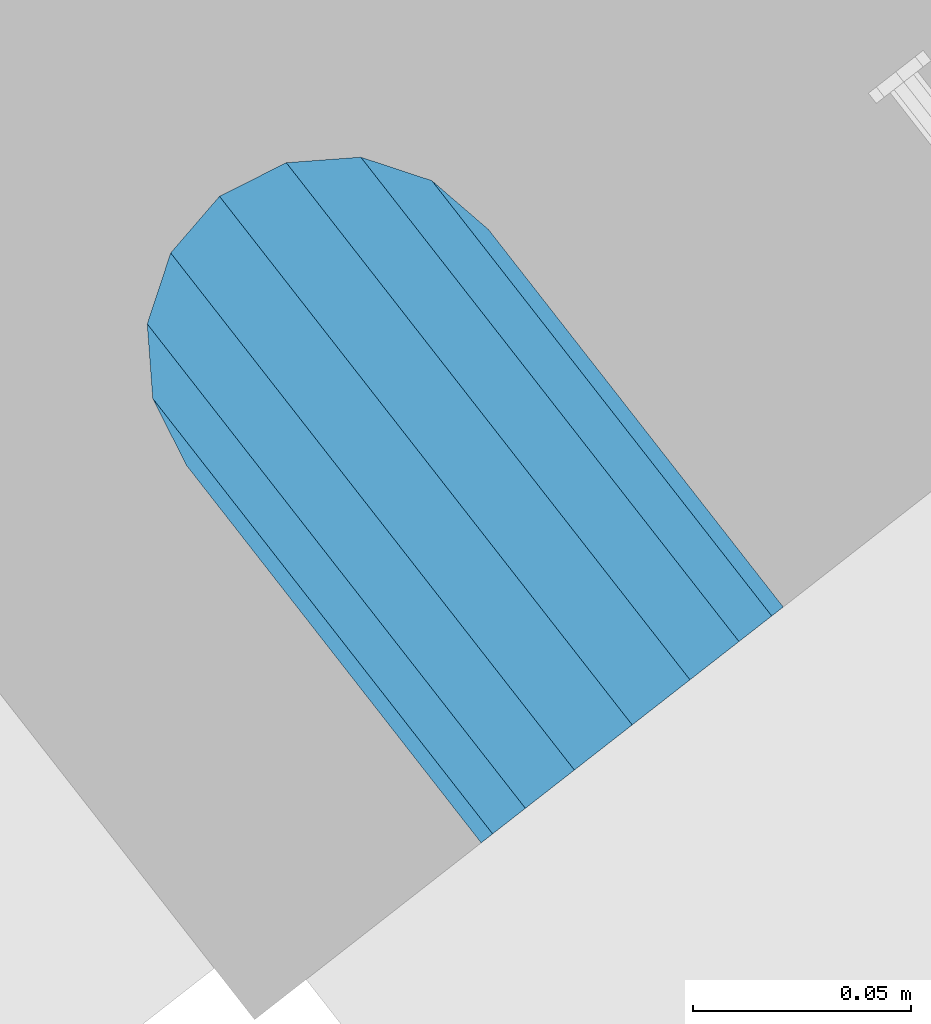
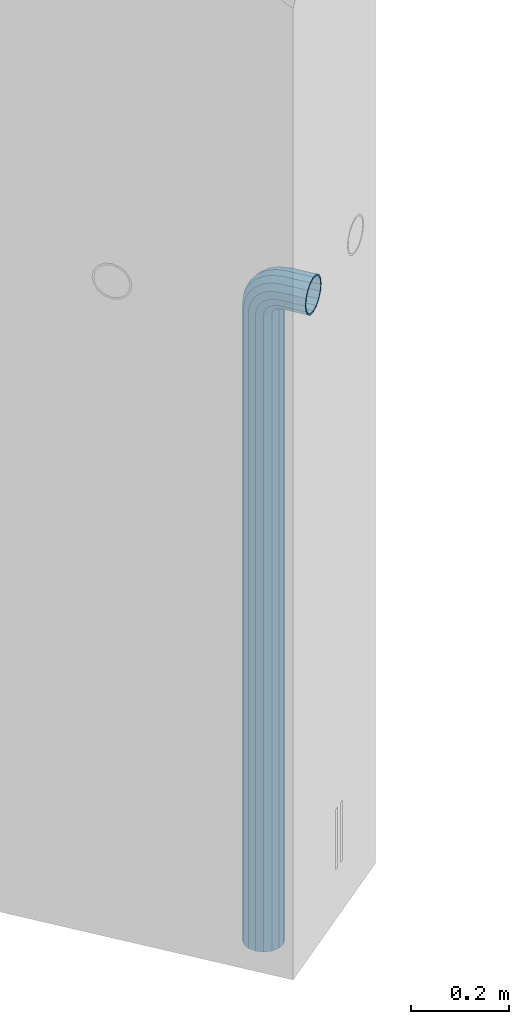
# One storey, part 4 of 42: 1 beam, 2 elements without a shape of their own.
"""IFC2X3 building model written with IfcOpenShell, lengths in millimetres."""

from ifc_helpers import new_model, si_unit, frame, origin_with_axes, place, context, subcontext, project, spatial, faceted_brep, material, type_object, element, aggregate, save


model = new_model("IFC2X3")

# Units and contexts
model_context = context("Model", 3, precision=1e-05, world=origin_with_axes())
body_context = subcontext(model_context, "Body", "Model", "MODEL_VIEW")
ifc_project = project(units=[si_unit("LENGTHUNIT", "METRE", prefix="MILLI"), si_unit("AREAUNIT", "SQUARE_METRE"), si_unit("VOLUMEUNIT", "CUBIC_METRE"), si_unit("MASSUNIT", "GRAM", prefix="KILO"), si_unit("TIMEUNIT", "SECOND"), si_unit("PLANEANGLEUNIT", "RADIAN"), si_unit("SOLIDANGLEUNIT", "STERADIAN"), si_unit("THERMODYNAMICTEMPERATUREUNIT", "DEGREE_CELSIUS"), si_unit("LUMINOUSINTENSITYUNIT", "LUMEN")], contexts=[model_context])

# Site, building, storey
site_placement = place(None, frame((171687.4, 84828.52, 14700.0), z_axis=(0.0, 0.0, 1.0), x_axis=(1.0, 0.0, 0.0)))
site = spatial("IfcSite", under=ifc_project, at=site_placement, CompositionType="ELEMENT")
building_placement = place(site_placement, origin_with_axes())
building = spatial("IfcBuilding", under=site, at=building_placement, Name="Undefined", CompositionType="ELEMENT")
storey_placement = place(building_placement, origin_with_axes())
storey = spatial("IfcBuildingStorey", under=building, at=storey_placement, Name="Undefined", CompositionType="ELEMENT", Elevation=0.0)

# Assemblies, beam
assembly_1_placement = place(storey_placement, origin_with_axes())
assembly_1 = element("IfcElementAssembly", 1, at=assembly_1_placement, inside=storey, AssemblyPlace="NOTDEFINED", PredefinedType="REINFORCEMENT_UNIT")
assembly_2_placement = place(assembly_1_placement, origin_with_axes())
assembly_2 = element("IfcElementAssembly", 2, at=assembly_2_placement, AssemblyPlace="NOTDEFINED", PredefinedType="RIGID_FRAME")
aggregate(assembly_1, [assembly_2])
ifc_material = material(Name="STEEL/NEG_BETON")
beam_type = type_object("IfcBeamType", PredefinedType="NOTDEFINED")
beam_placement = place(assembly_2_placement, frame((18184.6017728418, 265049.933547208, -1290.0), z_axis=(0.615386370178831, -0.788225611990706, 0.0), x_axis=(0.0, 0.0, 1.0)))
beam = element("IfcBeam", 3, at=beam_placement, type_object=beam_type, material=ifc_material, context=body_context, shape_type="Brep", body=[
    faceted_brep([(0.0, -43.999999753345, 2.88331648334861e-07), (0.0, -40.6506991838105, -16.8380707357428), (1590.0, -40.6506991838105, -16.8380707357428), (1589.99999999999, -43.999999753345, 2.88331648334861e-07), (0.0, -31.1126981254783, -31.1126980838017), (1590.0, -31.1126981254783, -31.1126980838017), (0.0, -16.8380707773322, -40.6506991419883), (1590.0, -16.8380707773322, -40.6506991419883), (0.0, 2.46742274612188e-07, -43.9999997114064), (1590.0, 2.46742274612188e-07, -43.9999997114064), (0.0, 16.8380712707876, -40.6506991418137), (1590.0, 16.8380712707876, -40.6506991418137), (0.0, 31.1126986189047, -31.1126980834524), (1590.0, 31.1126986189047, -31.1126980834524), (0.0, 40.6506996771204, -16.8380707352771), (1590.0, 40.6506996771204, -16.8380707352771), (0.0, 44.0000002465677, 2.88768205791712e-07), (1590.0, 44.0000002465677, 2.88768205791712e-07), (0.0, 40.6506996770622, 16.8380713128427), (1590.0, 40.6506996770622, 16.8380713128427), (0.0, 31.1126986187301, 31.1126986609306), (1590.0, 31.1126986187301, 31.1126986609306), (0.0, 16.8380712705839, 40.6506997191464), (1590.0, 16.8380712705839, 40.6506997191464), (0.0, 2.46509443968534e-07, 44.0000002885354), (1590.0, 2.46509443968534e-07, 44.0000002885354), (0.0, -16.8380707775359, 40.6506997189426), (1590.0, -16.8380707775359, 40.6506997189426), (0.0, -31.1126981256821, 31.1126986605814), (1590.0, -31.1126981256821, 31.1126986605814), (0.0, -40.6506991838978, 16.838071312377), (1590.0, -40.6506991838978, 16.838071312377), (4.47878846898675e-07, -40.0000000634464, 0.0), (4.47878846898675e-07, -36.9551813638827, 15.3073372946019), (1590.0, -36.9551810538396, 15.3073375829845), (1589.99999999999, -39.999999753345, 2.88360752165318e-07), (4.47937054559588e-07, -28.2842713108694, 28.284271247463), (1590.0, -28.2842710008845, 28.2842715359002), (4.4800981413573e-07, -15.3073373580119, 36.9551813004509), (1590.0, -15.3073370480561, 36.9551815889135), (4.48068021796644e-07, -6.34463503956795e-08, 40.0), (1590.0, 2.46538547798991e-07, 40.0000002885645), (4.48140781372786e-07, 15.3073372311774, 36.9551813004509), (1590.0, 15.3073375411332, 36.9551815890882), (4.48213540948927e-07, 28.2842711840058, 28.284271247463), (1590.0, 28.2842714939907, 28.2842715361621), (4.48271748609841e-07, 36.95518123699, 15.3073372946019), (1590.0, 36.9551815469749, 15.3073375833046), (4.48286300525069e-07, 39.9999999365536, 0.0), (1590.0, 40.0000002465677, 2.88768205791712e-07), (4.48271748609841e-07, 36.95518123699, -15.3073372946019), (1590.0, 36.9551815470913, -15.3073370058555), (4.48213540948927e-07, 28.2842711840058, -28.284271247463), (1590.0, 28.2842714941071, -28.2842709587712), (4.48140781372786e-07, 15.3073372311774, -36.9551813004509), (1590.0, 15.3073375413369, -36.9551810117846), (4.48068021796644e-07, -6.34463503956795e-08, -40.0), (1590.0, 2.46742274612188e-07, -39.9999997114064), (4.4800981413573e-07, -15.3073373580119, -36.9551813004509), (1590.0, -15.3073370479106, -36.9551810119592), (4.47937054559588e-07, -28.2842713108694, -28.284271247463), (1590.0, -28.284271000739, -28.2842709590332), (4.47878846898675e-07, -36.9551813638827, -15.3073372946019), (1590.0, -36.9551810537523, -15.3073370062048), (1602.94095225512, -43.9999997540726, 1.70370897403336), (1598.5829387913, -40.6506991846254, 17.9680366410757), (1594.88839337186, -31.1126981263515, 31.7562678573595), (1592.41977704577, -16.8380707782635, 40.9692694107944), (1591.55291427061, 2.45810952037573e-07, 44.2044453310082), (1592.41977704577, 16.8380712698563, 40.969269410969), (1594.88839337186, 31.1126986180025, 31.7562678576505), (1598.5829387913, 40.6506996763346, 17.9680366415123), (1602.94095225512, 44.0000002458692, 1.70370897452813), (1607.29896571893, 40.6506996763928, -14.5606186925434), (1610.99351113838, 31.112698618148, -28.3488499088271), (1613.46212746447, 16.83807127006, -37.561851462262), (1614.32899023963, 2.4601467885077e-07, -40.7970273824176), (1613.46212746447, -16.8380707780307, -37.5618514623784), (1610.99351113838, -31.1126981262059, -28.348849909089), (1607.29896571893, -40.650699184509, -14.5606186929217), (1613.29371405922, 2.45985575020313e-07, -36.9333240772539), (1612.50565699089, 15.3073375405802, -33.9922550588963), (1610.26146033081, 28.2842714934086, -25.6167991012626), (1606.90278267677, 36.9551815463637, -13.0820434500929), (1602.94095225512, 40.0000002458692, 1.70370897449902), (1598.97912183347, 36.9551815463055, 16.4894613990327), (1595.62044417943, 28.2842714932631, 29.024217050086), (1593.37624751934, 15.3073375403765, 37.3996730076324), (1592.58819045102, 2.45781848207116e-07, 40.3407420258154), (1593.37624751934, -15.3073370488128, 37.3996730074577), (1595.62044417943, -28.2842710016412, 29.0242170498241), (1598.97912183347, -36.9551810545672, 16.4894613986544), (1602.94095225512, -39.9999997540726, 1.70370897406247), (1606.90278267677, -36.955181054509, -13.0820434504712), (1610.26146033081, -28.2842710014374, -25.6167991015245), (1612.50565699089, -15.307337048609, -33.9922550590418), (1630.55634918609, 31.112698618148, -20.2456570709182), (1635.32534971524, 16.8380712700309, -28.5058082887845), (1623.41903551202, 40.6506996764219, -7.883467157837), (1614.99999999999, 44.0000002458692, 6.69873009974253), (1606.58096448796, 40.6506996763346, 21.2809273572639), (1599.44365081389, 31.1126986180025, 33.6431172702578), (1594.67465028474, 16.8380712698563, 41.9032684879785), (1592.99999999999, 2.45752744376659e-07, 44.8038478659873), (1594.67465028474, -16.8380707782635, 41.9032684878039), (1599.44365081389, -31.1126981263515, 33.6431172699668), (1606.58096448796, -40.6506991846254, 21.2809273568855), (1614.99999999999, -43.9999997540726, 6.69873009927687), (1623.41903551202, -40.6506991845672, -7.88346715827356), (1630.55634918609, -31.1126981262059, -20.2456570712384), (1635.32534971524, -16.8380707780598, -28.5058082889591), (1636.99999999999, 2.45956471189857e-07, -31.4063876669679), (1633.47759065022, -15.3073370486381, -25.3053957082157), (1634.99999999999, 2.45985575020313e-07, -27.9422860518389), (1629.14213562372, -28.2842710014665, -17.7961673284299), (1622.65366864729, -36.9551810545381, -6.55781286209822), (1614.99999999999, -39.9999997541017, 6.69873009933508), (1607.34633135269, -36.9551810545381, 19.9552730607684), (1600.85786437626, -28.2842710016121, 31.1936275271582), (1596.52240934976, -15.3073370487837, 38.7028559070604), (1594.99999999999, 2.45810952037573e-07, 41.3397462508583), (1596.52240934976, 15.3073375404056, 38.702855907206), (1600.85786437626, 28.2842714932631, 31.1936275275075), (1607.34633135269, 36.9551815462473, 19.9552730610885), (1614.99999999999, 40.0000002458692, 6.69873009974253), (1622.65366864729, 36.9551815463346, -6.55781286169076), (1629.14213562372, 28.2842714933795, -17.7961673281679), (1633.47759065022, 15.3073375405511, -25.305395708041), (1647.35533905931, 31.1126986181189, -7.35533877040143), (1654.09972428659, 16.8380712700018, -14.0997239977587), (1637.26165326252, 40.6506996763928, 2.73834702643217), (1625.35533905931, 44.0000002458401, 14.6446612296568), (1613.4490248561, 40.6506996763346, 26.5509754328523), (1603.35533905931, 31.1126986179734, 36.6446612295404), (1596.61095383203, 16.8380712698563, 43.3890464567812), (1594.24264068711, 2.45810952037573e-07, 45.7573596016155), (1596.61095383203, -16.8380707782344, 43.3890464565775), (1603.35533905931, -31.1126981263806, 36.6446612292202), (1613.4490248561, -40.6506991846254, 26.5509754324157), (1625.35533905931, -43.9999997541017, 14.644661229162), (1637.26165326252, -40.6506991845672, 2.73834702599561), (1647.35533905931, -31.1126981262641, -7.35533877075068), (1654.09972428659, -16.838070778118, -14.0997239979333), (1656.46803743151, 2.45956471189857e-07, -16.4680371427676), (1651.48659835683, -15.3073370486381, -11.4865980681498), (1653.63961030677, 2.45956471189857e-07, -13.6396100180573), (1645.35533905931, -28.2842710015248, -5.35533877072157), (1636.17926106223, -36.955181054509, 3.82073922632844), (1625.35533905931, -39.9999997541017, 14.6446612291911), (1614.53141705639, -36.9551810545672, 25.4685832321702), (1605.35533905931, -28.2842710016121, 34.6446612292784), (1599.22407976179, -15.3073370487837, 40.775920526823), (1597.07106781185, 2.45781848207116e-07, 42.9289324768179), (1599.22407976179, 15.3073375403765, 40.7759205269977), (1605.35533905931, 28.2842714932631, 34.6446612295404), (1614.53141705639, 36.9551815462764, 25.4685832324903), (1625.35533905931, 40.0000002458401, 14.6446612296277), (1636.17926106223, 36.9551815463346, 3.82073922670679), (1645.35533905931, 28.2842714933795, -5.35533877045964), (1651.48659835683, 15.307337540522, -11.4865980680042), (1660.24565735981, 31.1126986180607, 9.44365110280341), (1668.50580857761, 16.8380712699436, 4.67465057360823), (1647.88346744676, 40.6506996763055, 16.5809647768911), (1633.3012701892, 44.000000245811, 25.0000002889719), (1618.71907293164, 40.6506996763055, 33.4190358009655), (1606.35688301859, 31.1126986179734, 40.5563494749367), (1598.09673180079, 16.8380712698563, 45.3253500040737), (1595.19615242269, 2.45781848207116e-07, 47.00000028871), (1598.09673180079, -16.8380707782635, 45.32535000387), (1606.35688301859, -31.1126981263806, 40.5563494746748), (1618.71907293164, -40.6506991846545, 33.419035800558), (1633.3012701892, -43.9999997541308, 25.0000002884772), (1647.88346744676, -40.6506991845963, 16.5809647764836), (1660.24565735981, -31.1126981262933, 9.44365110251238), (1668.50580857761, -16.8380707781762, 4.67465057340451), (1671.40638795571, 2.459273673594e-07, 3.00000028876821), (1665.30539599684, -15.3073370486964, 6.52240963847726), (1667.94228634057, 2.45898263528943e-07, 5.00000028876821), (1657.79616761703, -28.2842710015539, 10.8578646648966), (1646.55781315062, -36.9551810545672, 17.3463316412526), (1633.3012701892, -39.9999997541308, 25.0000002885063), (1620.04472722778, -36.9551810546254, 32.6536689358181), (1608.80637276137, -28.2842710016412, 39.1421359122905), (1601.29714438156, -15.3073370488128, 43.4775909388554), (1598.66025403783, 2.45781848207116e-07, 45.0000002886809), (1601.29714438156, 15.3073375403765, 43.4775909390009), (1608.80637276137, 28.2842714932631, 39.1421359125816), (1620.04472722778, 36.9551815462473, 32.6536689362256), (1633.3012701892, 40.0000002458401, 25.0000002889428), (1646.55781315062, 36.9551815463055, 17.346331641631), (1657.79616761703, 28.2842714933213, 10.8578646651586), (1665.30539599684, 15.3073375404638, 6.52240963859367), (1668.34885019768, 31.1126986180316, 29.0064891505172), (1677.56185175105, 16.8380712698563, 26.5378728243522), (1654.56061898146, 40.6506996763055, 32.7010345700255), (1638.29629131443, 44.0000002457818, 37.0590480338433), (1622.0319636474, 40.6506996763055, 41.4170614976319), (1608.24373243118, 31.1126986179734, 45.1116069169948), (1599.03073087781, 16.8380712698563, 47.5802232430142), (1595.79555495772, 2.45781848207116e-07, 48.4470860181027), (1599.03073087781, -16.8380707782635, 47.5802232428396), (1608.24373243118, -31.1126981263806, 45.1116069167037), (1622.0319636474, -40.6506991846836, 41.4170614971954), (1638.29629131443, -43.9999997541599, 37.0590480333485), (1654.56061898146, -40.6506991846254, 32.701034569589), (1668.34885019768, -31.1126981263515, 29.006489150197), (1677.56185175105, -16.8380707782053, 26.5378728241776), (1680.79702767114, 2.4584005586803e-07, 25.6710100491182), (1673.99225534772, -15.3073370487546, 27.4943432977598), (1676.93332436598, 2.4584005586803e-07, 26.7062862295134), (1665.61679939011, -28.284271001583, 29.7385399577906), (1653.082043739, -36.9551810545963, 33.0972176117939), (1638.29629131443, -39.9999997541599, 37.0590480334067), (1623.51053888986, -36.9551810546545, 41.0208784550487), (1610.97578323875, -28.2842710016412, 44.3795561091392), (1602.60032728114, -15.3073370487837, 46.6237527692865), (1599.65925826287, 2.45810952037573e-07, 47.4118098377076), (1602.60032728114, 15.3073375403474, 46.623752769432), (1610.97578323875, 28.284271493234, 44.3795561094012), (1623.51053888986, 36.9551815462182, 41.0208784554561), (1638.29629131443, 40.0000002457818, 37.0590480338142), (1653.082043739, 36.9551815462473, 33.097217612114), (1665.61679939011, 28.2842714932631, 29.7385399580817), (1673.99225534772, 15.3073375404347, 27.4943432979344), (1671.11269837217, -31.1126981263806, 50.0000002885645), (1656.83807102403, -40.6506991847127, 50.0000002885063), (1680.65069943045, -16.8380707782635, 50.0000002886227), (1683.99999999996, 2.45781848207116e-07, 50.0000002887391), (1680.65069943045, 16.8380712698563, 50.0000002887973), (1671.11269837217, 31.1126986179734, 50.0000002888555), (1656.83807102403, 40.6506996762473, 50.0000002889428), (1639.99999999997, 44.0000002457236, 50.0000002889137), (1623.16192897591, 40.6506996762473, 50.0000002889428), (1608.88730162777, 31.1126986179734, 50.0000002888555), (1599.34930056949, 16.8380712698563, 50.0000002887973), (1595.99999999998, 2.45781848207116e-07, 50.0000002887391), (1599.34930056949, -16.8380707782635, 50.0000002886227), (1608.88730162777, -31.1126981263806, 50.0000002885645), (1623.16192897591, -40.6506991846836, 50.0000002885063), (1640.0, -43.999999754189, 50.0000002885063), (1676.95518130041, -15.3073370488128, 50.0000002886227), (1679.99999999996, 2.45781848207116e-07, 50.0000002887391), (1668.28427124742, -28.2842710016703, 50.0000002885645), (1655.30733729457, -36.9551810546545, 50.0000002885354), (1640.0, -39.999999754189, 50.0000002885063), (1624.69266270537, -36.9551810546545, 50.0000002885354), (1611.71572875252, -28.2842710016703, 50.0000002885645), (1603.04481869953, -15.3073370488128, 50.0000002886227), (1599.99999999998, 2.45781848207116e-07, 50.0000002887391), (1603.04481869953, 15.3073375403765, 50.0000002887973), (1611.71572875252, 28.284271493234, 50.0000002888555), (1624.69266270537, 36.9551815461891, 50.0000002888846), (1639.99999999997, 40.0000002457236, 50.0000002889137), (1655.30733729457, 36.9551815461891, 50.0000002889137), (1668.28427124742, 28.284271493234, 50.0000002888555), (1676.95518130041, 15.3073375403765, 50.0000002887973), (1656.83807102406, -40.6506991848582, 110.000000288477), (1640.0, -43.9999997543346, 110.000000288477), (1671.11269837221, -31.1126981265552, 110.000000288535), (1680.6506994305, -16.838070778409, 110.000000288594), (1684.0, 2.45607225224376e-07, 110.00000028871), (1680.6506994305, 16.8380712696817, 110.000000288768), (1671.11269837221, 31.1126986177987, 110.000000288826), (1656.83807102406, 40.6506996761018, 110.000000288914), (1640.0, 44.0000002455781, 110.000000288914), (1623.16192897594, 40.6506996761018, 110.000000288914), (1608.88730162779, 31.1126986177987, 110.000000288826), (1599.3493005695, 16.8380712696817, 110.000000288768), (1596.0, 2.45607225224376e-07, 110.00000028871), (1599.3493005695, -16.838070778409, 110.000000288594), (1608.88730162779, -31.1126981265552, 110.000000288535), (1623.16192897594, -40.6506991848582, 110.000000288477), (1624.6926627054, -36.9551810548001, 110.000000288535), (1640.0, -39.9999997543346, 110.000000288477), (1611.71572875254, -28.2842710018158, 110.000000288535), (1603.04481869955, -15.3073370489583, 110.000000288594), (1600.0, 2.45607225224376e-07, 110.00000028871), (1603.04481869955, 15.3073375402309, 110.000000288768), (1611.71572875254, 28.2842714930885, 110.000000288856), (1624.6926627054, 36.9551815460436, 110.000000288856), (1640.0, 40.0000002455781, 110.000000288885), (1655.3073372946, 36.9551815460436, 110.000000288856), (1668.28427124746, 28.2842714930885, 110.000000288856), (1676.95518130045, 15.3073375402309, 110.000000288768), (1680.0, 2.45607225224376e-07, 110.00000028871), (1676.95518130045, -15.3073370489583, 110.000000288594), (1668.28427124746, -28.2842710018158, 110.000000288535), (1655.3073372946, -36.9551810548001, 110.000000288535)], [[[0, 1, 2, 3]], [[1, 4, 5, 2]], [[4, 6, 7, 5]], [[6, 8, 9, 7]], [[8, 10, 11, 9]], [[10, 12, 13, 11]], [[12, 14, 15, 13]], [[14, 16, 17, 15]], [[16, 18, 19, 17]], [[18, 20, 21, 19]], [[20, 22, 23, 21]], [[22, 24, 25, 23]], [[24, 26, 27, 25]], [[26, 28, 29, 27]], [[28, 30, 31, 29]], [[30, 0, 3, 31]], [[32, 33, 34, 35]], [[33, 36, 37, 34]], [[36, 38, 39, 37]], [[38, 40, 41, 39]], [[40, 42, 43, 41]], [[42, 44, 45, 43]], [[44, 46, 47, 45]], [[46, 48, 49, 47]], [[48, 50, 51, 49]], [[50, 52, 53, 51]], [[52, 54, 55, 53]], [[54, 56, 57, 55]], [[56, 58, 59, 57]], [[58, 60, 61, 59]], [[60, 62, 63, 61]], [[62, 32, 35, 63]], [[30, 28, 26, 24, 22, 20, 18, 16, 14, 12, 10, 8, 6, 4, 1, 0], [62, 60, 58, 56, 54, 52, 50, 48, 46, 44, 42, 40, 38, 36, 33, 32]], [[31, 3, 64, 65]], [[29, 31, 65, 66]], [[27, 29, 66, 67]], [[25, 27, 67, 68]], [[23, 25, 68, 69]], [[21, 23, 69, 70]], [[19, 21, 70, 71]], [[17, 19, 71, 72]], [[15, 17, 72, 73]], [[13, 15, 73, 74]], [[11, 13, 74, 75]], [[9, 11, 75, 76]], [[7, 9, 76, 77]], [[5, 7, 77, 78]], [[2, 5, 78, 79]], [[3, 2, 79, 64]], [[55, 57, 80, 81]], [[53, 55, 81, 82]], [[51, 53, 82, 83]], [[49, 51, 83, 84]], [[47, 49, 84, 85]], [[45, 47, 85, 86]], [[43, 45, 86, 87]], [[41, 43, 87, 88]], [[39, 41, 88, 89]], [[37, 39, 89, 90]], [[34, 37, 90, 91]], [[35, 34, 91, 92]], [[63, 35, 92, 93]], [[61, 63, 93, 94]], [[59, 61, 94, 95]], [[57, 59, 95, 80]], [[74, 96, 97, 75]], [[73, 98, 96, 74]], [[72, 99, 98, 73]], [[71, 100, 99, 72]], [[70, 101, 100, 71]], [[69, 102, 101, 70]], [[68, 103, 102, 69]], [[67, 104, 103, 68]], [[66, 105, 104, 67]], [[65, 106, 105, 66]], [[64, 107, 106, 65]], [[79, 108, 107, 64]], [[78, 109, 108, 79]], [[77, 110, 109, 78]], [[76, 111, 110, 77]], [[75, 97, 111, 76]], [[95, 112, 113, 80]], [[94, 114, 112, 95]], [[93, 115, 114, 94]], [[92, 116, 115, 93]], [[91, 117, 116, 92]], [[90, 118, 117, 91]], [[89, 119, 118, 90]], [[88, 120, 119, 89]], [[87, 121, 120, 88]], [[86, 122, 121, 87]], [[85, 123, 122, 86]], [[84, 124, 123, 85]], [[83, 125, 124, 84]], [[82, 126, 125, 83]], [[81, 127, 126, 82]], [[80, 113, 127, 81]], [[96, 128, 129, 97]], [[98, 130, 128, 96]], [[99, 131, 130, 98]], [[100, 132, 131, 99]], [[101, 133, 132, 100]], [[102, 134, 133, 101]], [[103, 135, 134, 102]], [[104, 136, 135, 103]], [[105, 137, 136, 104]], [[106, 138, 137, 105]], [[107, 139, 138, 106]], [[108, 140, 139, 107]], [[109, 141, 140, 108]], [[110, 142, 141, 109]], [[111, 143, 142, 110]], [[97, 129, 143, 111]], [[112, 144, 145, 113]], [[114, 146, 144, 112]], [[115, 147, 146, 114]], [[116, 148, 147, 115]], [[117, 149, 148, 116]], [[118, 150, 149, 117]], [[119, 151, 150, 118]], [[120, 152, 151, 119]], [[121, 153, 152, 120]], [[122, 154, 153, 121]], [[123, 155, 154, 122]], [[124, 156, 155, 123]], [[125, 157, 156, 124]], [[126, 158, 157, 125]], [[127, 159, 158, 126]], [[113, 145, 159, 127]], [[128, 160, 161, 129]], [[130, 162, 160, 128]], [[131, 163, 162, 130]], [[132, 164, 163, 131]], [[133, 165, 164, 132]], [[134, 166, 165, 133]], [[135, 167, 166, 134]], [[136, 168, 167, 135]], [[137, 169, 168, 136]], [[138, 170, 169, 137]], [[139, 171, 170, 138]], [[140, 172, 171, 139]], [[141, 173, 172, 140]], [[142, 174, 173, 141]], [[143, 175, 174, 142]], [[129, 161, 175, 143]], [[144, 176, 177, 145]], [[146, 178, 176, 144]], [[147, 179, 178, 146]], [[148, 180, 179, 147]], [[149, 181, 180, 148]], [[150, 182, 181, 149]], [[151, 183, 182, 150]], [[152, 184, 183, 151]], [[153, 185, 184, 152]], [[154, 186, 185, 153]], [[155, 187, 186, 154]], [[156, 188, 187, 155]], [[157, 189, 188, 156]], [[158, 190, 189, 157]], [[159, 191, 190, 158]], [[145, 177, 191, 159]], [[160, 192, 193, 161]], [[162, 194, 192, 160]], [[163, 195, 194, 162]], [[164, 196, 195, 163]], [[165, 197, 196, 164]], [[166, 198, 197, 165]], [[167, 199, 198, 166]], [[168, 200, 199, 167]], [[169, 201, 200, 168]], [[170, 202, 201, 169]], [[171, 203, 202, 170]], [[172, 204, 203, 171]], [[173, 205, 204, 172]], [[174, 206, 205, 173]], [[175, 207, 206, 174]], [[161, 193, 207, 175]], [[176, 208, 209, 177]], [[178, 210, 208, 176]], [[179, 211, 210, 178]], [[180, 212, 211, 179]], [[181, 213, 212, 180]], [[182, 214, 213, 181]], [[183, 215, 214, 182]], [[184, 216, 215, 183]], [[185, 217, 216, 184]], [[186, 218, 217, 185]], [[187, 219, 218, 186]], [[188, 220, 219, 187]], [[189, 221, 220, 188]], [[190, 222, 221, 189]], [[191, 223, 222, 190]], [[177, 209, 223, 191]], [[205, 224, 225, 204]], [[206, 226, 224, 205]], [[207, 227, 226, 206]], [[193, 228, 227, 207]], [[192, 229, 228, 193]], [[194, 230, 229, 192]], [[195, 231, 230, 194]], [[196, 232, 231, 195]], [[197, 233, 232, 196]], [[198, 234, 233, 197]], [[199, 235, 234, 198]], [[200, 236, 235, 199]], [[201, 237, 236, 200]], [[202, 238, 237, 201]], [[203, 239, 238, 202]], [[204, 225, 239, 203]], [[208, 240, 241, 209]], [[210, 242, 240, 208]], [[211, 243, 242, 210]], [[212, 244, 243, 211]], [[213, 245, 244, 212]], [[214, 246, 245, 213]], [[215, 247, 246, 214]], [[216, 248, 247, 215]], [[217, 249, 248, 216]], [[218, 250, 249, 217]], [[219, 251, 250, 218]], [[220, 252, 251, 219]], [[221, 253, 252, 220]], [[222, 254, 253, 221]], [[223, 255, 254, 222]], [[209, 241, 255, 223]], [[239, 225, 256, 257]], [[225, 224, 258, 256]], [[224, 226, 259, 258]], [[226, 227, 260, 259]], [[227, 228, 261, 260]], [[228, 229, 262, 261]], [[229, 230, 263, 262]], [[230, 231, 264, 263]], [[231, 232, 265, 264]], [[232, 233, 266, 265]], [[233, 234, 267, 266]], [[234, 235, 268, 267]], [[235, 236, 269, 268]], [[236, 237, 270, 269]], [[237, 238, 271, 270]], [[238, 239, 257, 271]], [[244, 245, 272, 273]], [[245, 246, 274, 272]], [[246, 247, 275, 274]], [[247, 248, 276, 275]], [[248, 249, 277, 276]], [[249, 250, 278, 277]], [[250, 251, 279, 278]], [[251, 252, 280, 279]], [[252, 253, 281, 280]], [[253, 254, 282, 281]], [[254, 255, 283, 282]], [[255, 241, 284, 283]], [[241, 240, 285, 284]], [[240, 242, 286, 285]], [[242, 243, 287, 286]], [[243, 244, 273, 287]], [[258, 259, 260, 261, 262, 263, 264, 265, 266, 267, 268, 269, 270, 271, 257, 256], [274, 275, 276, 277, 278, 279, 280, 281, 282, 283, 284, 285, 286, 287, 273, 272]]]),
])
aggregate(assembly_2, [beam])

save(model, "model.ifc")
